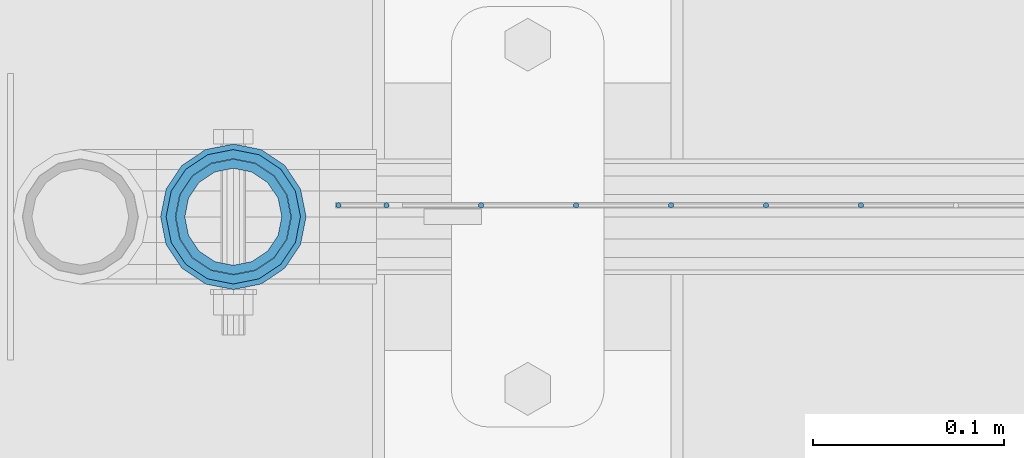
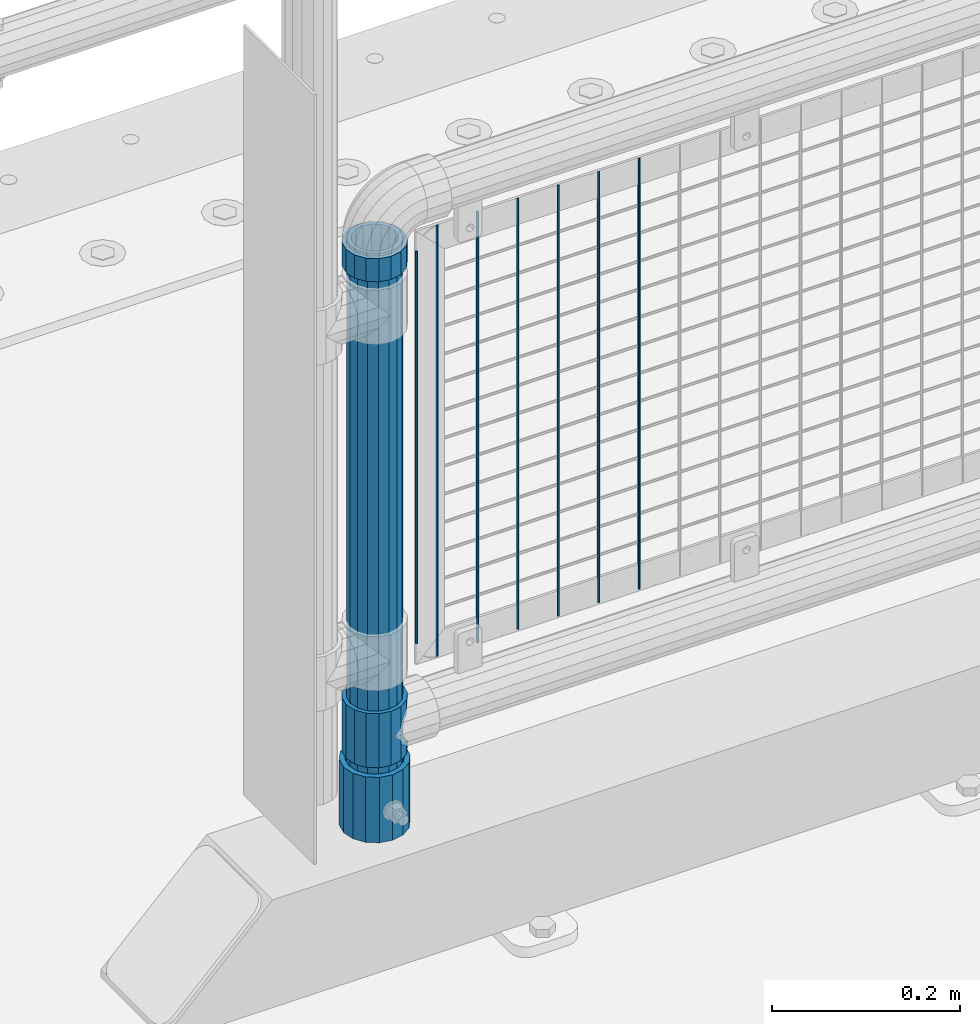
# One storey, part 65 of 257: 11 columns.
"""IFC2X3 building model written with IfcOpenShell, lengths in millimetres."""

from ifc_helpers import new_model, si_unit, frame, origin_with_axes, place, context, subcontext, project, spatial, faceted_brep, material, type_object, element, save


model = new_model("IFC2X3")

# Units and contexts
model_context = context("Model", 3, precision=1e-05, world=origin_with_axes())
body_context = subcontext(model_context, "Body", "Model", "MODEL_VIEW")
ifc_project = project(units=[si_unit("LENGTHUNIT", "METRE", prefix="MILLI"), si_unit("AREAUNIT", "SQUARE_METRE"), si_unit("VOLUMEUNIT", "CUBIC_METRE"), si_unit("MASSUNIT", "GRAM", prefix="KILO"), si_unit("TIMEUNIT", "SECOND"), si_unit("PLANEANGLEUNIT", "RADIAN"), si_unit("SOLIDANGLEUNIT", "STERADIAN"), si_unit("THERMODYNAMICTEMPERATUREUNIT", "DEGREE_CELSIUS"), si_unit("LUMINOUSINTENSITYUNIT", "LUMEN")], contexts=[model_context])

# Site, building, storey
site_placement = place(None, origin_with_axes())
site = spatial("IfcSite", under=ifc_project, at=site_placement, CompositionType="ELEMENT")
building_placement = place(site_placement, origin_with_axes())
building = spatial("IfcBuilding", under=site, at=building_placement, Name="Standard", CompositionType="ELEMENT")
storey_placement = place(building_placement, origin_with_axes())
storey = spatial("IfcBuildingStorey", under=building, at=storey_placement, Name="Undefined", CompositionType="ELEMENT", Elevation=0.0)

# Columns
ifc_material_1 = material()
column_type_1 = type_object("IfcColumnType", PredefinedType="NOTDEFINED")
column_1_placement = place(storey_placement, frame((43070.9999998042, 10664.5, 168.019999999998), z_axis=(0.0, 1.0, 0.0), x_axis=(0.0, 0.0, 1.0)))
element("IfcColumn", 1, at=column_1_placement, inside=storey, type_object=column_type_1, material=ifc_material_1, context=body_context, shape_type="Brep", body=[
    faceted_brep([(0.0, -31.75, 0.0), (0.0, -29.3331751572332, 12.1501989775916), (85.0, -29.3331751572332, 12.1501989775916), (85.0, -31.75, 0.0), (0.0, -22.4506403026753, 22.4506403026735), (85.0, -22.4506403026753, 22.4506403026735), (0.0, -12.1501989775934, 29.3331751572332), (85.0, -12.1501989775934, 29.3331751572332), (0.0, 0.0, 31.75), (85.0, 0.0, 31.75), (0.0, 12.1501989775934, 29.3331751572332), (85.0, 12.1501989775934, 29.3331751572332), (0.0, 22.4506403026753, 22.4506403026735), (85.0, 22.4506403026753, 22.4506403026735), (0.0, 29.3331751572332, 12.1501989775916), (85.0, 29.3331751572332, 12.1501989775916), (0.0, 31.75, 0.0), (85.0, 31.75, 0.0), (0.0, 29.3331751572332, -12.1501989775916), (85.0, 29.3331751572332, -12.1501989775916), (0.0, 22.4506403026753, -22.4506403026735), (85.0, 22.4506403026753, -22.4506403026735), (0.0, 12.1501989775934, -29.3331751572332), (85.0, 12.1501989775934, -29.3331751572332), (0.0, 0.0, -31.75), (85.0, 0.0, -31.75), (0.0, -12.1501989775934, -29.3331751572332), (85.0, -12.1501989775934, -29.3331751572332), (0.0, -22.4506403026753, -22.4506403026735), (85.0, -22.4506403026753, -22.4506403026735), (0.0, -29.3331751572332, -12.1501989775916), (85.0, -29.3331751572332, -12.1501989775916), (0.0, -38.0500000000029, 0.0), (0.0, -35.1536162120537, -14.561104601491), (85.0, -35.1536162120537, -14.561104601491), (85.0, -38.0500000000029, 0.0), (0.0, -26.9054130241493, -26.9054130241475), (85.0, -26.9054130241493, -26.9054130241475), (0.0, -14.5611046014892, -35.1536162120537), (85.0, -14.5611046014892, -35.1536162120537), (0.0, 0.0, -38.0499999999993), (85.0, 0.0, -38.0499999999993), (0.0, 14.5611046014892, -35.1536162120537), (85.0, 14.5611046014892, -35.1536162120537), (0.0, 26.9054130241493, -26.9054130241475), (85.0, 26.9054130241493, -26.9054130241475), (0.0, 35.1536162120537, -14.561104601491), (85.0, 35.1536162120537, -14.561104601491), (0.0, 38.0500000000029, 0.0), (85.0, 38.0500000000029, 0.0), (0.0, 35.1536162120537, 14.561104601491), (85.0, 35.1536162120537, 14.561104601491), (0.0, 26.9054130241493, 26.9054130241475), (85.0, 26.9054130241493, 26.9054130241475), (0.0, 14.5611046014892, 35.1536162120537), (85.0, 14.5611046014892, 35.1536162120537), (0.0, 0.0, 38.0499999999993), (85.0, 0.0, 38.0499999999993), (0.0, -14.5611046014892, 35.1536162120537), (85.0, -14.5611046014892, 35.1536162120537), (0.0, -26.9054130241493, 26.9054130241475), (85.0, -26.9054130241493, 26.9054130241475), (0.0, -35.1536162120537, 14.561104601491), (85.0, -35.1536162120537, 14.561104601491)], [[[0, 1, 2, 3]], [[1, 4, 5, 2]], [[4, 6, 7, 5]], [[6, 8, 9, 7]], [[8, 10, 11, 9]], [[10, 12, 13, 11]], [[12, 14, 15, 13]], [[14, 16, 17, 15]], [[16, 18, 19, 17]], [[18, 20, 21, 19]], [[20, 22, 23, 21]], [[22, 24, 25, 23]], [[24, 26, 27, 25]], [[26, 28, 29, 27]], [[28, 30, 31, 29]], [[30, 0, 3, 31]], [[32, 33, 34, 35]], [[33, 36, 37, 34]], [[36, 38, 39, 37]], [[38, 40, 41, 39]], [[40, 42, 43, 41]], [[42, 44, 45, 43]], [[44, 46, 47, 45]], [[46, 48, 49, 47]], [[48, 50, 51, 49]], [[50, 52, 53, 51]], [[52, 54, 55, 53]], [[54, 56, 57, 55]], [[56, 58, 59, 57]], [[58, 60, 61, 59]], [[60, 62, 63, 61]], [[62, 32, 35, 63]], [[37, 39, 41, 43, 45, 47, 49, 51, 53, 55, 57, 59, 61, 63, 35, 34], [5, 7, 9, 11, 13, 15, 17, 19, 21, 23, 25, 27, 29, 31, 3, 2]], [[62, 60, 58, 56, 54, 52, 50, 48, 46, 44, 42, 40, 38, 36, 33, 32], [30, 28, 26, 24, 22, 20, 18, 16, 14, 12, 10, 8, 6, 4, 1, 0]]]),
])
ifc_material_2 = material(Name="Misc_Undefined")
column_type_2 = type_object("IfcColumnType", PredefinedType="NOTDEFINED")
column_2_placement = place(storey_placement, frame((43071.0, 10664.5, 263.52), z_axis=(-1.0, 0.0, 0.0), x_axis=(0.0, 0.0, 1.0)))
element("IfcColumn", 2, at=column_2_placement, inside=storey, type_object=column_type_2, material=ifc_material_2, context=body_context, shape_type="Brep", body=[
    faceted_brep([(63.1897438117172, 11.6144421722802, -32.8397438117245), (63.1897438117172, 11.6144421722802, -28.0397438117143), (56.6106908090114, 21.4606908090118, -21.4606908090136), (56.6106908090114, 21.4606908090118, -27.1226768591077), (61.9623795176756, 13.4513226476338, -32.4743655677739), (46.7644421722801, 28.0397438117179, -11.6144421722784), (46.7644421722801, 28.0397438117179, -20.0882031229921), (51.5310424080039, 24.8548033587067, -24.8548033587067), (35.1500000000015, 30.35, 0.0), (35.1499999999996, 30.3500000000004, -16.6306603983758), (23.5355578277192, 28.0397438117179, -11.6144421722784), (23.5355578277192, 28.0397438117179, -20.0882031229921), (18.7689575919954, 24.8548033587067, -24.8548033587067), (13.6893091909879, 21.4606908090118, -21.4606908090136), (13.6893091909879, 21.4606908090118, -27.1226768591077), (8.3376204823237, 13.4513226476338, -32.4743655677739), (7.11025618828211, 11.6144421722802, -28.0397438117143), (7.11025618828211, 11.6144421722802, -32.8397438117245), (4.79999999999961, 0.0, -30.3499999999985), (4.79999999999961, 0.0, -35.1500000000015), (7.11025618828205, -11.6144421722802, -28.0397438117143), (7.11025618828205, -11.6144421722802, -32.8397438117245), (13.6893091909879, -21.4606908090118, -21.4606908090136), (13.6893091909879, -21.4606908090118, -27.1226768591077), (8.33762048232484, -13.4513226476338, -32.4743655677739), (23.5355578277191, -28.0397438117179, -11.6144421722784), (23.5355578277191, -28.0397438117179, -20.0882031229849), (18.7689575919987, -24.8548033587067, -24.8548033587067), (35.1500000000015, -30.35, 0.0), (35.1499999999996, -30.3500000000004, -16.6306603983685), (46.7644421722801, -28.0397438117179, -11.6144421722784), (46.7644421722801, -28.0397438117179, -20.0882031229849), (51.5310424080038, -24.8548033587067, -24.8548033587067), (56.6106908090114, -21.4606908090118, -21.4606908090136), (56.6106908090114, -21.4606908090118, -27.1226768591077), (61.9623795176756, -13.4513226476338, -32.4743655677739), (63.1897438117172, -11.6144421722802, -28.0397438117143), (63.1897438117172, -11.6144421722802, -32.8397438117245), (65.4999999999997, 0.0, -30.3499999999985), (65.4999999999997, 0.0, -35.1500000000015), (70.2999999999993, -11.6144421722802, -28.0397438117143), (70.2999999999993, 0.0, -30.3499999999985), (70.2999999999993, -21.4606908090118, -21.4606908090136), (70.2999999999993, -28.0397438117179, -11.6144421722784), (70.2999999999993, -30.3500000000004, 0.0), (0.0, -28.0397438117179, -11.6144421722784), (0.0, -30.3500000000004, 0.0), (0.0, -21.4606908090118, -21.4606908090136), (0.0, -11.6144421722802, -28.0397438117143), (0.0, 0.0, -30.3499999999985), (0.0, 11.6144421722802, -28.0397438117143), (0.0, 21.4606908090118, -21.4606908090136), (0.0, 28.0397438117179, -11.6144421722784), (0.0, 30.3500000000004, 0.0), (0.0, -24.8548033587067, -24.8548033587067), (0.0, -13.4513226476338, -32.4743655677739), (0.0, 0.0, -35.1499999999996), (0.0, 13.4513226476338, -32.4743655677739), (0.0, 24.8548033587067, -24.8548033587067), (0.0, -32.4743655677721, 13.4513226476338), (0.0, -35.1499999999996, 0.0), (70.2999999999993, -35.1499999999996, 0.0), (70.2999999999993, -32.4743655677721, 13.4513226476338), (0.0, -24.8548033587067, 24.8548033587067), (70.2999999999993, -24.8548033587067, 24.8548033587067), (0.0, -13.4513226476338, 32.4743655677739), (70.2999999999993, -13.4513226476338, 32.4743655677739), (0.0, 0.0, 35.1499999999996), (70.2999999999993, 0.0, 35.1500000000015), (0.0, 13.4513226476338, 32.4743655677739), (70.2999999999993, 13.4513226476338, 32.4743655677739), (0.0, 24.8548033587067, 24.8548033587067), (70.2999999999993, 24.8548033587067, 24.8548033587067), (0.0, 32.4743655677721, 13.4513226476338), (70.2999999999993, 32.4743655677721, 13.4513226476338), (0.0, 35.1499999999996, 0.0), (70.2999999999993, 35.1499999999996, 0.0), (0.0, 32.4743655677721, -13.4513226476338), (70.2999999999993, 32.4743655677721, -13.4513226476338), (70.2999999999993, 24.8548033587067, -24.8548033587067), (70.2999999999993, 13.4513226476338, -32.4743655677739), (70.2999999999993, 0.0, -35.1500000000015), (70.2999999999993, -13.4513226476338, -32.4743655677739), (70.2999999999993, -24.8548033587067, -24.8548033587067), (70.2999999999993, -32.4743655677721, -13.4513226476338), (0.0, -32.4743655677721, -13.4513226476338), (0.0, 28.0397438117179, 11.6144421722784), (0.0, 21.4606908090118, 21.4606908090136), (0.0, 11.6144421722802, 28.0397438117143), (0.0, 0.0, 30.3499999999985), (0.0, -11.6144421722802, 28.0397438117143), (0.0, -21.4606908090118, 21.4606908090136), (0.0, -28.0397438117179, 11.6144421722784), (70.2999999999993, 28.0397438117179, 11.6144421722784), (70.2999999999993, 21.4606908090118, 21.4606908090136), (70.2999999999993, 11.6144421722802, 28.0397438117143), (70.2999999999993, 0.0, 30.3499999999985), (70.2999999999993, -11.6144421722802, 28.0397438117143), (70.2999999999993, -21.4606908090118, 21.4606908090136), (70.2999999999993, -28.0397438117179, 11.6144421722784), (70.2999999999993, 30.3500000000004, 0.0), (70.2999999999993, 28.0397438117179, -11.6144421722784), (70.2999999999993, 21.4606908090118, -21.4606908090136), (70.2999999999993, 11.6144421722802, -28.0397438117143)], [[[0, 1, 2, 3, 4]], [[3, 2, 5, 6, 7]], [[6, 5, 8, 9]], [[9, 8, 10, 11]], [[12, 11, 10, 13, 14]], [[15, 14, 13, 16, 17]], [[17, 16, 18, 19]], [[19, 18, 20, 21]], [[21, 20, 22, 23, 24]], [[23, 22, 25, 26, 27]], [[26, 25, 28, 29]], [[29, 28, 30, 31]], [[32, 31, 30, 33, 34]], [[35, 34, 33, 36, 37]], [[37, 36, 38, 39]], [[39, 38, 1, 0]], [[40, 41, 38, 36]], [[42, 40, 36, 33]], [[43, 42, 33, 30]], [[44, 43, 30, 28]], [[45, 46, 28, 25]], [[47, 45, 25, 22]], [[48, 47, 22, 20]], [[49, 48, 20, 18]], [[50, 49, 18, 16]], [[51, 50, 16, 13]], [[52, 51, 13, 10]], [[53, 52, 10, 8]], [[27, 54, 55, 24, 23]], [[24, 55, 56, 19, 21]], [[56, 57, 15, 17, 19]], [[57, 58, 12, 14, 15]], [[59, 60, 61, 62]], [[63, 59, 62, 64]], [[65, 63, 64, 66]], [[67, 65, 66, 68]], [[69, 67, 68, 70]], [[71, 69, 70, 72]], [[73, 71, 72, 74]], [[75, 73, 74, 76]], [[77, 75, 76, 78]], [[9, 11, 12, 58, 77, 78, 79, 7, 6]], [[7, 79, 80, 4, 3]], [[4, 80, 81, 39, 0]], [[82, 83, 32, 34, 35]], [[81, 82, 35, 37, 39]], [[83, 84, 85, 54, 27, 26, 29, 31, 32]], [[60, 85, 84, 61]], [[59, 63, 65, 67, 69, 71, 73, 75, 77, 58, 57, 56, 55, 54, 85, 60], [45, 47, 48, 49, 50, 51, 52, 53, 86, 87, 88, 89, 90, 91, 92, 46]], [[87, 86, 93, 94]], [[88, 87, 94, 95]], [[89, 88, 95, 96]], [[90, 89, 96, 97]], [[91, 90, 97, 98]], [[92, 91, 98, 99]], [[28, 46, 92, 99, 44]], [[83, 82, 81, 80, 79, 78, 76, 74, 72, 70, 68, 66, 64, 62, 61, 84], [98, 97, 96, 95, 94, 93, 100, 101, 102, 103, 41, 40, 42, 43, 44, 99]], [[86, 53, 8, 100, 93]], [[101, 100, 8, 5]], [[102, 101, 5, 2]], [[103, 102, 2, 1]], [[41, 103, 1, 38]]]),
])
column_3_placement = place(storey_placement, frame((43071.0, 10664.5, 894.849999999999), z_axis=(-1.0, 0.0, 0.0), x_axis=(0.0, 0.0, 1.0)))
element("IfcColumn", 3, at=column_3_placement, inside=storey, type_object=column_type_2, material=ifc_material_2, context=body_context, shape_type="Brep", body=[
    faceted_brep([(0.0, -30.3500000000004, 0.0), (0.0, -28.0397438117179, 11.6144421722784), (30.0, -28.0397438117179, 11.6144421722805), (30.0, -30.3500000000004, 0.0), (0.0, -21.4606908090118, 21.4606908090136), (30.0, -21.4606908090118, 21.4606908090117), (0.0, -11.6144421722802, 28.0397438117143), (30.0, -11.6144421722802, 28.0397438117175), (0.0, 0.0, 30.3499999999985), (30.0, 0.0, 30.35), (0.0, 11.6144421722802, 28.0397438117143), (30.0, 11.6144421722802, 28.0397438117175), (0.0, 21.4606908090118, 21.4606908090136), (30.0, 21.4606908090118, 21.4606908090117), (0.0, 28.0397438117179, 11.6144421722784), (30.0, 28.0397438117179, 11.6144421722805), (0.0, 30.3500000000004, 0.0), (30.0, 30.3500000000004, 0.0), (0.0, 28.0397438117179, -11.6144421722784), (30.0, 28.0397438117179, -11.6144421722805), (0.0, 21.4606908090118, -21.4606908090136), (30.0, 21.4606908090118, -21.4606908090117), (0.0, 11.6144421722802, -28.0397438117143), (30.0, 11.6144421722802, -28.0397438117175), (0.0, 0.0, -30.3499999999985), (30.0, 0.0, -30.35), (0.0, -11.6144421722802, -28.0397438117143), (30.0, -11.6144421722802, -28.0397438117175), (0.0, -21.4606908090118, -21.4606908090136), (30.0, -21.4606908090118, -21.4606908090117), (0.0, -28.0397438117179, -11.6144421722784), (30.0, -28.0397438117179, -11.6144421722805), (0.0, -35.1499999999996, 0.0), (0.0, -32.4743655677721, -13.4513226476338), (30.0, -32.4743655677721, -13.4513226476329), (30.0, -35.1499999999996, 0.0), (0.0, -24.8548033587067, -24.8548033587067), (30.0, -24.8548033587067, -24.8548033587072), (0.0, -13.4513226476338, -32.4743655677739), (30.0, -13.4513226476338, -32.4743655677717), (0.0, 0.0, -35.1499999999996), (30.0, 0.0, -35.15), (0.0, 13.4513226476338, -32.4743655677739), (30.0, 13.4513226476338, -32.4743655677717), (0.0, 24.8548033587067, -24.8548033587067), (30.0, 24.8548033587067, -24.8548033587072), (0.0, 32.4743655677721, -13.4513226476338), (30.0, 32.4743655677721, -13.4513226476329), (0.0, 35.1499999999996, 0.0), (30.0, 35.1499999999996, 0.0), (0.0, 32.4743655677721, 13.4513226476338), (30.0, 32.4743655677721, 13.4513226476329), (0.0, 24.8548033587067, 24.8548033587067), (30.0, 24.8548033587067, 24.8548033587072), (0.0, 13.4513226476338, 32.4743655677739), (30.0, 13.4513226476338, 32.4743655677717), (0.0, 0.0, 35.1499999999996), (30.0, 0.0, 35.15), (0.0, -13.4513226476338, 32.4743655677739), (30.0, -13.4513226476338, 32.4743655677717), (0.0, -24.8548033587067, 24.8548033587067), (30.0, -24.8548033587067, 24.8548033587072), (0.0, -32.4743655677721, 13.4513226476338), (30.0, -32.4743655677721, 13.4513226476329)], [[[0, 1, 2, 3]], [[1, 4, 5, 2]], [[4, 6, 7, 5]], [[6, 8, 9, 7]], [[8, 10, 11, 9]], [[10, 12, 13, 11]], [[12, 14, 15, 13]], [[14, 16, 17, 15]], [[16, 18, 19, 17]], [[18, 20, 21, 19]], [[20, 22, 23, 21]], [[22, 24, 25, 23]], [[24, 26, 27, 25]], [[26, 28, 29, 27]], [[28, 30, 31, 29]], [[30, 0, 3, 31]], [[32, 33, 34, 35]], [[33, 36, 37, 34]], [[36, 38, 39, 37]], [[38, 40, 41, 39]], [[40, 42, 43, 41]], [[42, 44, 45, 43]], [[44, 46, 47, 45]], [[46, 48, 49, 47]], [[48, 50, 51, 49]], [[50, 52, 53, 51]], [[52, 54, 55, 53]], [[54, 56, 57, 55]], [[56, 58, 59, 57]], [[58, 60, 61, 59]], [[60, 62, 63, 61]], [[62, 32, 35, 63]], [[37, 39, 41, 43, 45, 47, 49, 51, 53, 55, 57, 59, 61, 63, 35, 34], [5, 7, 9, 11, 13, 15, 17, 19, 21, 23, 25, 27, 29, 31, 3, 2]], [[62, 60, 58, 56, 54, 52, 50, 48, 46, 44, 42, 40, 38, 36, 33, 32], [30, 28, 26, 24, 22, 20, 18, 16, 14, 12, 10, 8, 6, 4, 1, 0]]]),
])
column_type_3 = type_object("IfcColumnType", PredefinedType="NOTDEFINED")
column_4_placement = place(storey_placement, frame((43070.9999998042, 10664.5, 168.019999999998), z_axis=(-1.0, 0.0, 0.0), x_axis=(0.0, 0.0, 1.0)))
element("IfcColumn", 4, at=column_4_placement, inside=storey, type_object=column_type_3, material=ifc_material_1, context=body_context, shape_type="Brep", body=[
    faceted_brep([(0.0, -25.3500000000004, 0.0), (0.0, -23.4203461491616, 9.70102501045767), (760.0, -23.4203461491616, 9.70102501045767), (760.0, -25.3500000000004, 0.0), (0.0, -17.9251569030785, 17.9251569030821), (760.0, -17.9251569030785, 17.9251569030821), (0.0, -9.70102501045585, 23.4203461491634), (760.0, -9.70102501045585, 23.4203461491634), (0.0, 0.0, 25.3499999999985), (760.0, 0.0, 25.3499999999985), (0.0, 9.70102501045585, 23.4203461491634), (760.0, 9.70102501045585, 23.4203461491634), (0.0, 17.9251569030785, 17.9251569030821), (760.0, 17.9251569030785, 17.9251569030821), (0.0, 23.4203461491616, 9.70102501045767), (760.0, 23.4203461491616, 9.70102501045767), (0.0, 25.3500000000004, 0.0), (760.0, 25.3500000000004, 0.0), (0.0, 23.4203461491616, -9.70102501045767), (760.0, 23.4203461491616, -9.70102501045767), (0.0, 17.9251569030785, -17.9251569030821), (760.0, 17.9251569030785, -17.9251569030821), (0.0, 9.70102501045585, -23.4203461491634), (760.0, 9.70102501045585, -23.4203461491634), (0.0, 0.0, -25.3499999999985), (760.0, 0.0, -25.3499999999985), (0.0, -9.70102501045585, -23.4203461491634), (760.0, -9.70102501045585, -23.4203461491634), (0.0, -17.9251569030785, -17.9251569030821), (760.0, -17.9251569030785, -17.9251569030821), (0.0, -23.4203461491616, -9.70102501045767), (760.0, -23.4203461491616, -9.70102501045767), (0.0, -30.1499999999996, 0.0), (0.0, -27.8549679052157, -11.5379054858058), (760.0, -27.8549679052157, -11.5379054858058), (760.0, -30.1499999999996, 0.0), (0.0, -21.3192694527752, -21.3192694527752), (760.0, -21.3192694527752, -21.3192694527752), (0.0, -11.5379054858076, -27.8549679052157), (760.0, -11.5379054858076, -27.8549679052157), (0.0, 0.0, -30.1500000000015), (760.0, 0.0, -30.1500000000015), (0.0, 11.5379054858076, -27.8549679052157), (760.0, 11.5379054858076, -27.8549679052157), (0.0, 21.3192694527752, -21.3192694527752), (760.0, 21.3192694527752, -21.3192694527752), (0.0, 27.8549679052157, -11.5379054858058), (760.0, 27.8549679052157, -11.5379054858058), (0.0, 30.1499999999996, 0.0), (760.0, 30.1499999999996, 0.0), (0.0, 27.8549679052157, 11.5379054858058), (760.0, 27.8549679052157, 11.5379054858058), (0.0, 21.3192694527752, 21.3192694527752), (760.0, 21.3192694527752, 21.3192694527752), (0.0, 11.5379054858076, 27.8549679052157), (760.0, 11.5379054858076, 27.8549679052157), (0.0, 0.0, 30.1500000000015), (760.0, 0.0, 30.1500000000015), (0.0, -11.5379054858076, 27.8549679052157), (760.0, -11.5379054858076, 27.8549679052157), (0.0, -21.3192694527752, 21.3192694527752), (760.0, -21.3192694527752, 21.3192694527752), (0.0, -27.8549679052157, 11.5379054858058), (760.0, -27.8549679052157, 11.5379054858058)], [[[0, 1, 2, 3]], [[1, 4, 5, 2]], [[4, 6, 7, 5]], [[6, 8, 9, 7]], [[8, 10, 11, 9]], [[10, 12, 13, 11]], [[12, 14, 15, 13]], [[14, 16, 17, 15]], [[16, 18, 19, 17]], [[18, 20, 21, 19]], [[20, 22, 23, 21]], [[22, 24, 25, 23]], [[24, 26, 27, 25]], [[26, 28, 29, 27]], [[28, 30, 31, 29]], [[30, 0, 3, 31]], [[32, 33, 34, 35]], [[33, 36, 37, 34]], [[36, 38, 39, 37]], [[38, 40, 41, 39]], [[40, 42, 43, 41]], [[42, 44, 45, 43]], [[44, 46, 47, 45]], [[46, 48, 49, 47]], [[48, 50, 51, 49]], [[50, 52, 53, 51]], [[52, 54, 55, 53]], [[54, 56, 57, 55]], [[56, 58, 59, 57]], [[58, 60, 61, 59]], [[60, 62, 63, 61]], [[62, 32, 35, 63]], [[37, 39, 41, 43, 45, 47, 49, 51, 53, 55, 57, 59, 61, 63, 35, 34], [5, 7, 9, 11, 13, 15, 17, 19, 21, 23, 25, 27, 29, 31, 3, 2]], [[62, 60, 58, 56, 54, 52, 50, 48, 46, 44, 42, 40, 38, 36, 33, 32], [30, 28, 26, 24, 22, 20, 18, 16, 14, 12, 10, 8, 6, 4, 1, 0]]]),
])
column_type_4 = type_object("IfcColumnType", Name="D3", PredefinedType="NOTDEFINED")
for number, where, z_axis, x_axis in (
    (5, (43399.275, 10670.5, 353.02), (-1.0, 0.0, 0.0), (0.0, 0.0, 1.0)),
    (6, (43349.62, 10670.5, 353.02), (-1.0, 0.0, 0.0), (0.0, 0.0, 1.0)),
    (7, (43299.965, 10670.5, 353.02), (-1.0, 0.0, 0.0), (0.0, 0.0, 1.0)),
    (8, (43250.3103448276, 10670.5, 353.02), (-0.999999999851374, 0.0, 1.72409999974503e-05), (1.72409999946567e-05, 0.0, 0.999999999851374)),
    (9, (43200.6551724138, 10670.5, 353.02), (-0.999999999962839, 0.0, 8.62099999968473e-06), (8.62099999949798e-06, 0.0, 0.999999999962839)),
):
    element("IfcColumn", number, at=place(storey_placement, frame(where, z_axis=z_axis, x_axis=x_axis)), inside=storey, type_object=column_type_4, material=ifc_material_2, ObjectType="D3", context=body_context, shape_type="Brep", body=[
        faceted_brep([(0.0, -1.5, -5.6843418860808e-14), (0.0, -0.750000000001819, -1.29903810567669), (560.0, -0.75, -1.29903810567339), (560.0, -1.5, 0.0), (7.27595761418343e-12, 0.749999999998181, -1.29903810567669), (560.0, 0.75, -1.29903810567339), (0.0, 1.5, -5.6843418860808e-14), (560.0, 1.5, 0.0), (7.27595761418343e-12, 0.749999999998181, 1.29903810567669), (560.0, 0.75, 1.29903810567339), (0.0, -0.750000000001819, 1.29903810567669), (560.0, -0.75, 1.29903810567339)], [[[0, 1, 2, 3]], [[1, 4, 5, 2]], [[4, 6, 7, 5]], [[6, 8, 9, 7]], [[8, 10, 11, 9]], [[10, 0, 3, 11]], [[5, 7, 9, 11, 3, 2]], [[10, 8, 6, 4, 1, 0]]]),
    ])
column_5_placement = place(storey_placement, frame((43126.0, 10670.5, 378.02), z_axis=(-1.0, 0.0, 0.0), x_axis=(0.0, 0.0, 1.0)))
element("IfcColumn", 10, at=column_5_placement, inside=storey, type_object=column_type_4, material=ifc_material_2, ObjectType="D3", context=body_context, shape_type="Brep", body=[
    faceted_brep([(0.0, -1.5, -5.6843418860808e-14), (0.0, -0.750000000001819, -1.29903810567669), (510.0, -0.75, -1.29903810567339), (510.0, -1.5, 0.0), (7.27595761418343e-12, 0.749999999998181, -1.29903810567669), (510.0, 0.75, -1.29903810567339), (0.0, 1.5, -5.6843418860808e-14), (510.0, 1.5, 0.0), (7.27595761418343e-12, 0.749999999998181, 1.29903810567669), (510.0, 0.75, 1.29903810567339), (0.0, -0.750000000001819, 1.29903810567669), (510.0, -0.75, 1.29903810567339)], [[[0, 1, 2, 3]], [[1, 4, 5, 2]], [[4, 6, 7, 5]], [[6, 8, 9, 7]], [[8, 10, 11, 9]], [[10, 0, 3, 11]], [[5, 7, 9, 11, 3, 2]], [[10, 8, 6, 4, 1, 0]]]),
])
column_6_placement = place(storey_placement, frame((43151.0, 10670.5, 353.02), z_axis=(-1.0, 0.0, 0.0), x_axis=(0.0, 0.0, 1.0)))
element("IfcColumn", 11, at=column_6_placement, inside=storey, type_object=column_type_4, material=ifc_material_2, ObjectType="D3", context=body_context, shape_type="Brep", body=[
    faceted_brep([(0.0, -1.5, -5.6843418860808e-14), (0.0, -0.750000000001819, -1.29903810567669), (560.0, -0.75, -1.29903810567339), (560.0, -1.5, 0.0), (7.27595761418343e-12, 0.749999999998181, -1.29903810567669), (560.0, 0.75, -1.29903810567339), (0.0, 1.5, -5.6843418860808e-14), (560.0, 1.5, 0.0), (7.27595761418343e-12, 0.749999999998181, 1.29903810567669), (560.0, 0.75, 1.29903810567339), (0.0, -0.750000000001819, 1.29903810567669), (560.0, -0.75, 1.29903810567339)], [[[0, 1, 2, 3]], [[1, 4, 5, 2]], [[4, 6, 7, 5]], [[6, 8, 9, 7]], [[8, 10, 11, 9]], [[10, 0, 3, 11]], [[5, 7, 9, 11, 3, 2]], [[10, 8, 6, 4, 1, 0]]]),
])

save(model, "model.ifc")
